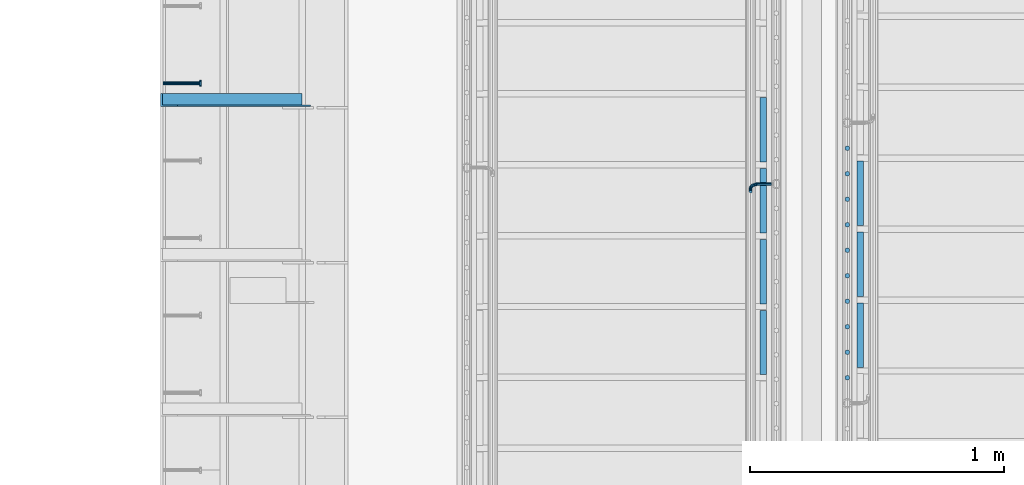
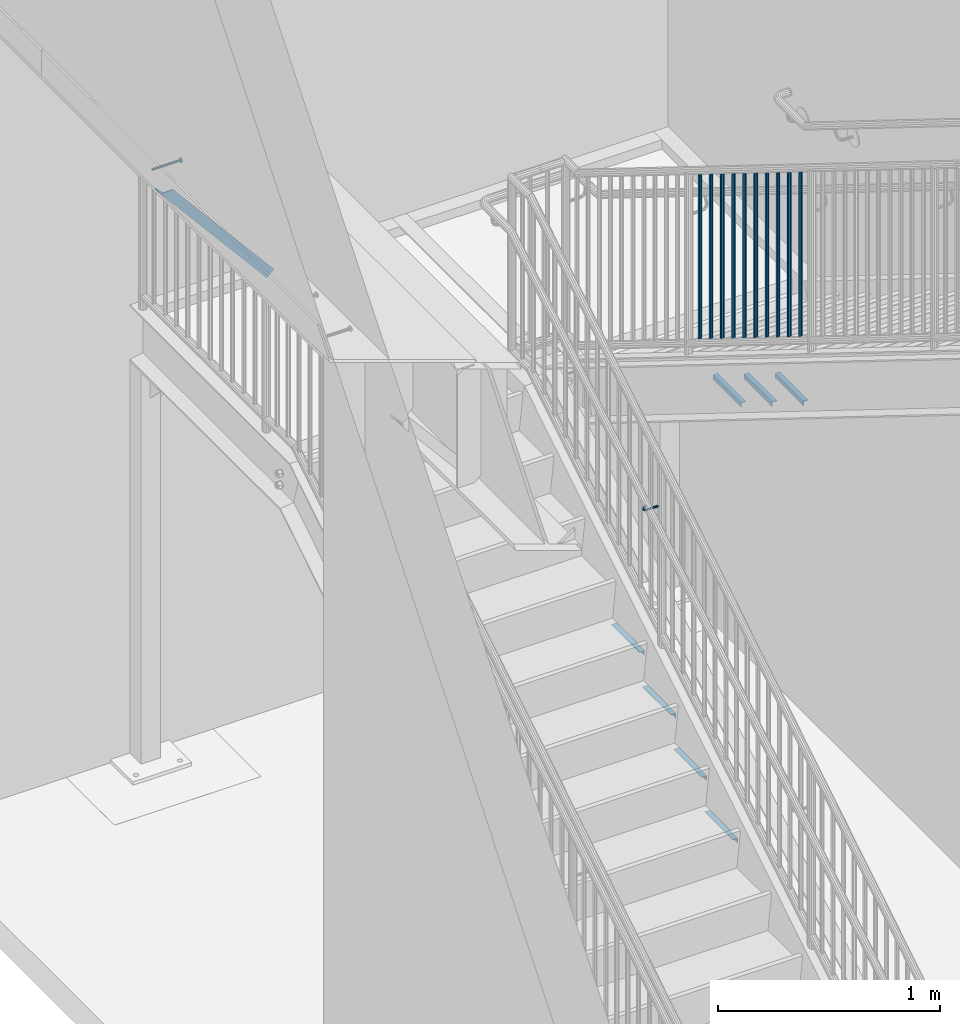
# One storey, part 1269 of 1763: 19 beams, 1 member, 6 elements without a shape of their own.
"""IFC2X3 building model written with IfcOpenShell, lengths in millimetres."""

from ifc_helpers import new_model, si_unit, frame, origin_with_axes, place, context, subcontext, project, spatial, faceted_brep, material, type_object, element, aggregate, save


model = new_model("IFC2X3")

# Units and contexts
model_context = context("Model", 3, precision=1e-05, world=origin_with_axes())
body_context = subcontext(model_context, "Body", "Model", "MODEL_VIEW")
ifc_project = project(units=[si_unit("LENGTHUNIT", "METRE", prefix="MILLI"), si_unit("AREAUNIT", "SQUARE_METRE"), si_unit("VOLUMEUNIT", "CUBIC_METRE"), si_unit("MASSUNIT", "GRAM", prefix="KILO"), si_unit("TIMEUNIT", "SECOND"), si_unit("PLANEANGLEUNIT", "RADIAN"), si_unit("SOLIDANGLEUNIT", "STERADIAN"), si_unit("THERMODYNAMICTEMPERATUREUNIT", "DEGREE_CELSIUS"), si_unit("LUMINOUSINTENSITYUNIT", "LUMEN")], contexts=[model_context])

# Site, building, storey
site_placement = place(None, origin_with_axes())
site = spatial("IfcSite", under=ifc_project, at=site_placement, CompositionType="ELEMENT")
building_placement = place(site_placement, origin_with_axes())
building = spatial("IfcBuilding", under=site, at=building_placement, Name="Undefined", CompositionType="ELEMENT")
storey_placement = place(building_placement, origin_with_axes())
storey = spatial("IfcBuildingStorey", under=building, at=storey_placement, Name="Undefined", CompositionType="ELEMENT", Elevation=0.0)

# Assembly, beam
assembly_1_placement = place(storey_placement, origin_with_axes())
assembly_1 = element("IfcElementAssembly", 1, at=assembly_1_placement, inside=storey, Name="HEADED STUD ANCHOR", AssemblyPlace="NOTDEFINED", PredefinedType="RIGID_FRAME")
ifc_material_1 = material(Name="STEEL/A108")
beam_type_1 = type_object("IfcBeamType", PredefinedType="NOTDEFINED")
beam_1_placement = place(assembly_1_placement, frame((-87975.5122736983, 35144.0750061035, 5268.91250001202), z_axis=(0.0, 0.0, -1.0), x_axis=(1.0, 0.0, 0.0)))
beam_1 = element("IfcBeam", 2, at=beam_1_placement, type_object=beam_type_1, material=ifc_material_1, Name="HEADED STUD ANCHOR", context=body_context, shape_type="Brep", body=[
    faceted_brep([(0.0, -3.1800000667572, 5.5), (0.0, -5.5, 3.1800000667572), (141.732000000002, -5.5, 3.1800000667572), (141.732000000002, -3.1800000667572, 5.5), (0.0, -6.34999999999491, 1.45519152283669e-11), (141.732000000002, -6.34999990463257, 0.0), (0.0, -5.5, -3.1800000667572), (141.732000000002, -5.5, -3.1800000667572), (0.0, -3.1800000667572, -5.5), (141.732000000002, -3.1800000667572, -5.5), (0.0, 0.0, -6.34999990463257), (141.732000000002, 0.0, -6.34999990463257), (0.0, 3.1800000667572, -5.5), (141.732000000002, 3.1800000667572, -5.5), (0.0, 5.5, -3.1800000667572), (141.732000000002, 5.5, -3.1800000667572), (0.0, 6.34999999999491, -2.91038304567337e-11), (141.732000000002, 6.34999990463257, 0.0), (0.0, 5.5, 3.1800000667572), (141.732000000002, 5.5, 3.1800000667572), (0.0, 3.1800000667572, 5.5), (141.732000000002, 3.1800000667572, 5.5), (0.0, 0.0, 6.34999990463257), (141.732000000002, 0.0, 6.34999990463257), (144.780000000001, -10.9899997711182, 6.34999990463257), (144.780000000001, -6.34000015258789, 10.9899997711182), (144.780000000001, -12.6999998092651, 0.0), (144.780000000001, -10.9899997711182, -6.34999990463257), (144.780000000001, -6.34000015258789, -10.9899997711182), (144.780000000001, 0.0, -12.6899995803833), (144.780000000001, 6.34000015258789, -10.9899997711182), (144.780000000001, 10.9899997711182, -6.34999990463257), (144.780000000001, 12.6999998092651, 0.0), (144.780000000001, 10.9899997711182, 6.34999990463257), (144.780000000001, 6.34000015258789, 10.9899997711182), (144.780000000001, 0.0, 12.6899995803833), (152.400000000001, -10.9899997711182, 6.34999990463257), (152.400000000001, -6.34000015258789, 10.9899997711182), (152.400000000001, -12.6999998092651, 0.0), (152.400000000001, -10.9899997711182, -6.34999990463257), (152.400000000001, -6.34000015258789, -10.9899997711182), (152.400000000001, 0.0, -12.6899995803833), (152.400000000001, 6.34000015258789, -10.9899997711182), (152.400000000001, 10.9899997711182, -6.34999990463257), (152.400000000001, 12.6999998092651, 0.0), (152.400000000001, 10.9899997711182, 6.34999990463257), (152.400000000001, 6.34000015258789, 10.9899997711182), (152.400000000001, 0.0, 12.6899995803833)], [[[0, 1, 2, 3]], [[1, 4, 5, 2]], [[4, 6, 7, 5]], [[6, 8, 9, 7]], [[8, 10, 11, 9]], [[10, 12, 13, 11]], [[12, 14, 15, 13]], [[14, 16, 17, 15]], [[16, 18, 19, 17]], [[18, 20, 21, 19]], [[20, 22, 23, 21]], [[22, 0, 3, 23]], [[22, 20, 18, 16, 14, 12, 10, 8, 6, 4, 1, 0]], [[3, 2, 24, 25]], [[2, 5, 26, 24]], [[5, 7, 27, 26]], [[7, 9, 28, 27]], [[9, 11, 29, 28]], [[11, 13, 30, 29]], [[13, 15, 31, 30]], [[15, 17, 32, 31]], [[17, 19, 33, 32]], [[19, 21, 34, 33]], [[21, 23, 35, 34]], [[23, 3, 25, 35]], [[25, 24, 36, 37]], [[24, 26, 38, 36]], [[26, 27, 39, 38]], [[27, 28, 40, 39]], [[28, 29, 41, 40]], [[29, 30, 42, 41]], [[30, 31, 43, 42]], [[31, 32, 44, 43]], [[32, 33, 45, 44]], [[33, 34, 46, 45]], [[34, 35, 47, 46]], [[35, 25, 37, 47]], [[38, 39, 40, 41, 42, 43, 44, 45, 46, 47, 37, 36]]]),
])
aggregate(assembly_1, [beam_1])

# Assembly, member
assembly_2_placement = place(storey_placement, origin_with_axes())
assembly_2 = element("IfcElementAssembly", 3, at=assembly_2_placement, inside=storey, Name="BEAM", AssemblyPlace="NOTDEFINED", PredefinedType="RIGID_FRAME")
ifc_material_2 = material(Name="STEEL/A36")
member_type = type_object("IfcMemberType", Name="L2X2X1/4", PredefinedType="NOTDEFINED")
member_placement = place(assembly_2_placement, frame((-87414.1929584935, 35077.4, 4557.35349338836), z_axis=(0.764183480307171, 0.0, 0.644998921259268), x_axis=(-0.644998921259266, 0.0, 0.764183480307173)))
member = element("IfcMember", 4, at=member_placement, type_object=member_type, material=ifc_material_2, Name="ANGLE", ObjectType="L2X2X1/4", context=body_context, shape_type="Brep", body=[
    faceted_brep([(-1.45519152283669e-11, 25.4000000000015, -25.3999999999869), (1.45519152283669e-11, 25.4000000000015, 25.3999999999796), (812.060911532491, 25.4000000000015, 25.400000001966), (854.937976763787, 25.4000000000015, -25.3999999979424), (1.45519152283669e-11, 19.0499999999993, 25.3999999999796), (812.060911532491, 19.0500000000029, 25.400000001966), (-7.27595761418343e-12, 19.0499999999993, -19.0499999999956), (849.578343609872, 19.0500000000029, -19.0499999979511), (-7.27595761418343e-12, -25.4000000000015, -19.0499999999956), (849.578343609872, -25.4000000000015, -19.0499999979511), (-1.45519152283669e-11, -25.4000000000015, -25.3999999999869), (854.937976763787, -25.4000000000015, -25.3999999979424)], [[[0, 1, 2, 3]], [[1, 4, 5, 2]], [[4, 6, 7, 5]], [[6, 8, 9, 7]], [[8, 10, 11, 9]], [[10, 0, 3, 11]], [[5, 7, 9, 11, 3, 2]], [[10, 8, 6, 4, 1, 0]]]),
])
aggregate(assembly_2, [member])

# Assembly, beam
assembly_3_placement = place(storey_placement, origin_with_axes())
assembly_3 = element("IfcElementAssembly", 5, at=assembly_3_placement, inside=storey, Name="RAIL", AssemblyPlace="NOTDEFINED", PredefinedType="RIGID_FRAME")
beam_type_2 = type_object("IfcBeamType", PredefinedType="NOTDEFINED")
beam_2_placement = place(assembly_3_placement, frame((-85578.3872739632, 34747.2000003714, 2823.89393381709), z_axis=(0.0, 0.849698797869672, 0.527268387919126), x_axis=(-1.0, 0.0, 0.0)))
beam_2 = element("IfcBeam", 6, at=beam_2_placement, type_object=beam_type_2, material=ifc_material_2, Name="RAIL", context=body_context, shape_type="Brep", body=[
    faceted_brep([(0.0, -6.34999999999491, 1.45519152283669e-11), (-1.13686837721616e-13, -4.49012806053361, -4.49012806058454), (50.8000030517578, -4.49012806053452, -4.49012806053361), (50.8000030517578, -6.35000000000036, 0.0), (0.0, 0.0, -6.34999990463257), (50.8000030517578, 0.0, -6.34999999999854), (0.0, 4.49012806054088, -4.49012806053452), (50.8000030517578, 4.49012806053452, -4.49012806053361), (0.0, 6.34999999999491, -2.91038304567337e-11), (50.8000030517578, 6.35000000000036, 0.0), (0.0, 4.49012806054088, 4.49012806053452), (50.8000030517578, 4.49012806053452, 4.49012806053361), (0.0, 0.0, 6.34999990463257), (50.8000030517578, 0.0, 6.34999999999854), (0.0, -4.49012806053361, 4.49012806055543), (50.8000030517578, -4.49012806053452, 4.49012806053361), (65.380241824867, -3.44981018867929, 0.0), (64.6684996473195, -1.73151257071549, 4.49012806053361), (62.9502020293439, 2.4168248427668, 6.34999999999854), (61.2319044113829, 6.5651622562491, 4.49012806053361), (60.5201622338354, 8.2834598742138, 0.0), (61.2319044113829, 6.5651622562491, -4.49012806053361), (62.9502020293439, 2.4168248427668, -6.34999999999854), (64.6684996473195, -1.73151257071549, -4.49012806053361), (76.425643354436, 6.12435969732724, -4.49012806053361), (77.7407714149595, 4.8092316367929, 0.0), (73.2506433544331, 9.29935969732742, -6.34999999999854), (70.0756433544302, 12.4743596973276, -4.49012806053361), (68.7605152938922, 13.7894877578619, 0.0), (70.0756433544302, 12.4743596973276, 4.49012806053361), (73.2506433544331, 9.29935969732742, 6.34999999999854), (76.425643354436, 6.12435969732724, 4.49012806053361), (84.2815156224679, 17.8815034044446, -4.49012806053361), (85.9998132404435, 17.1697612268908, 0.0), (80.1331782089983, 19.5998010224093, -6.34999999999854), (75.9848407955142, 21.3180986403731, -4.49012806053361), (74.2665431775386, 22.0298408179269, 0.0), (75.9848407955142, 21.3180986403731, 4.49012806053361), (80.1331782089983, 19.5998010224093, 6.34999999999854), (84.2815156224679, 17.8815034044446, 4.49012806053361), (87.0401311122987, 31.75, -4.49012806053361), (88.9000030517636, 31.75, 0.0), (82.5500030517578, 31.75, -6.34999999999854), (78.0598749912169, 31.75, -4.49012806053361), (76.200003051752, 31.75, 0.0), (78.0598749912169, 31.75, 4.49012806053361), (82.5500030517578, 31.75, 6.34999999999854), (87.0401311122987, 31.75, 4.49012806053361), (87.0401311122987, 57.1500015258789, -4.49012806053361), (88.9000030517636, 57.1500015258789, 0.0), (82.5500030517578, 57.1500015258789, -6.34999999999854), (78.0598749912169, 57.1500015258789, -4.49012806053361), (76.200003051752, 57.1500015258789, 0.0), (78.0598749912169, 57.1500015258789, 4.49012806053361), (82.5500030517578, 57.1500015258789, 6.34999999999854), (87.0401311122987, 57.1500015258789, 4.49012806053361)], [[[0, 1, 2, 3]], [[1, 4, 5, 2]], [[4, 6, 7, 5]], [[6, 8, 9, 7]], [[8, 10, 11, 9]], [[10, 12, 13, 11]], [[12, 14, 15, 13]], [[14, 0, 3, 15]], [[14, 12, 10, 8, 6, 4, 1, 0]], [[15, 3, 16, 17]], [[13, 15, 17, 18]], [[11, 13, 18, 19]], [[9, 11, 19, 20]], [[7, 9, 20, 21]], [[5, 7, 21, 22]], [[2, 5, 22, 23]], [[3, 2, 23, 16]], [[23, 24, 25, 16]], [[22, 26, 24, 23]], [[21, 27, 26, 22]], [[20, 28, 27, 21]], [[19, 29, 28, 20]], [[18, 30, 29, 19]], [[17, 31, 30, 18]], [[16, 25, 31, 17]], [[24, 32, 33, 25]], [[26, 34, 32, 24]], [[27, 35, 34, 26]], [[28, 36, 35, 27]], [[29, 37, 36, 28]], [[30, 38, 37, 29]], [[31, 39, 38, 30]], [[25, 33, 39, 31]], [[32, 40, 41, 33]], [[34, 42, 40, 32]], [[35, 43, 42, 34]], [[36, 44, 43, 35]], [[37, 45, 44, 36]], [[38, 46, 45, 37]], [[39, 47, 46, 38]], [[33, 41, 47, 39]], [[41, 40, 48, 49]], [[40, 42, 50, 48]], [[42, 43, 51, 50]], [[43, 44, 52, 51]], [[44, 45, 53, 52]], [[45, 46, 54, 53]], [[46, 47, 55, 54]], [[47, 41, 49, 55]], [[50, 51, 52, 53, 54, 55, 49, 48]]]),
])
aggregate(assembly_3, [beam_2])

# Assembly, beams
assembly_4_placement = place(storey_placement, origin_with_axes())
assembly_4 = element("IfcElementAssembly", 7, at=assembly_4_placement, inside=storey, Name="RAIL", AssemblyPlace="NOTDEFINED", PredefinedType="RIGID_FRAME")
beam_type_3 = type_object("IfcBeamType", PredefinedType="NOTDEFINED")
beam_3_placement = place(assembly_4_placement, frame((-85279.8721005486, 33984.0454545575, 5037.48386342587), z_axis=(1.0, 0.0, 0.0), x_axis=(0.0, 0.0, -1.0)))
beam_3 = element("IfcBeam", 8, at=beam_3_placement, type_object=beam_type_3, material=ifc_material_2, Name="PICKET", context=body_context, shape_type="Brep", body=[
    faceted_brep([(16.5092624764411, -9.52500000000146, 0.0), (18.2412682186596, -6.73519209080041, -6.73519209079677), (919.54586829654, -6.73519209080041, -6.73519209079677), (917.813862554322, -9.52500000000146, 0.0), (22.4226999716293, 0.0, -9.52499999999418), (923.727300049511, 0.0, -9.52499999999418), (26.6041317245999, 6.73519209080041, -6.73519209079677), (927.908731802481, 6.73519209080041, -6.73519209079677), (28.3361374668184, 9.52500000000146, 0.0), (929.6407375447, 9.52500000000146, 0.0), (26.6041317245999, 6.73519209080041, 6.73519209079677), (927.908731802481, 6.73519209080041, 6.73519209079677), (22.4226999716293, 0.0, 9.52499999999418), (923.727300049511, 0.0, 9.52499999999418), (18.2412682186596, -6.73519209080041, 6.73519209079677), (919.54586829654, -6.73519209080041, 6.73519209079677)], [[[0, 1, 2, 3]], [[1, 4, 5, 2]], [[4, 6, 7, 5]], [[6, 8, 9, 7]], [[8, 10, 11, 9]], [[10, 12, 13, 11]], [[12, 14, 15, 13]], [[14, 0, 3, 15]], [[5, 7, 9, 11, 13, 15, 3, 2]], [[14, 12, 10, 8, 6, 4, 1, 0]]]),
])
beam_4_placement = place(assembly_4_placement, frame((-85279.8721005486, 34084.4909091201, 4975.12397710232), z_axis=(1.0, 0.0, 0.0), x_axis=(0.0, 0.0, -1.0)))
beam_4 = element("IfcBeam", 9, at=beam_4_placement, type_object=beam_type_3, material=ifc_material_2, Name="PICKET", context=body_context, shape_type="Brep", body=[
    faceted_brep([(16.5092624764411, -9.52500000000146, 0.0), (18.2412682186596, -6.73519209080041, -6.73519209079677), (919.54586829654, -6.73519209080041, -6.73519209079677), (917.813862554322, -9.52500000000146, 0.0), (22.4226999716293, 0.0, -9.52499999999418), (923.727300049511, 0.0, -9.52499999999418), (26.6041317245999, 6.73519209080041, -6.73519209079677), (927.908731802481, 6.73519209080041, -6.73519209079677), (28.3361374668184, 9.52500000000146, 0.0), (929.6407375447, 9.52500000000146, 0.0), (26.6041317245999, 6.73519209080041, 6.73519209079677), (927.908731802481, 6.73519209080041, 6.73519209079677), (22.4226999716293, 0.0, 9.52499999999418), (923.727300049511, 0.0, 9.52499999999418), (18.2412682186596, -6.73519209080041, 6.73519209079677), (919.54586829654, -6.73519209080041, 6.73519209079677)], [[[0, 1, 2, 3]], [[1, 4, 5, 2]], [[4, 6, 7, 5]], [[6, 8, 9, 7]], [[8, 10, 11, 9]], [[10, 12, 13, 11]], [[12, 14, 15, 13]], [[14, 0, 3, 15]], [[5, 7, 9, 11, 13, 15, 3, 2]], [[14, 12, 10, 8, 6, 4, 1, 0]]]),
])
beam_5_placement = place(assembly_4_placement, frame((-85279.8721005486, 34184.9363636827, 4912.76409077877), z_axis=(1.0, 0.0, 0.0), x_axis=(0.0, 0.0, -1.0)))
beam_5 = element("IfcBeam", 10, at=beam_5_placement, type_object=beam_type_3, material=ifc_material_2, Name="PICKET", context=body_context, shape_type="Brep", body=[
    faceted_brep([(16.5092624764411, -9.52500000000146, 0.0), (18.2412682186596, -6.73519209080041, -6.73519209079677), (919.54586829654, -6.73519209080041, -6.73519209079677), (917.813862554322, -9.52500000000146, 0.0), (22.4226999716293, 0.0, -9.52499999999418), (923.727300049511, 0.0, -9.52499999999418), (26.6041317245999, 6.73519209080041, -6.73519209079677), (927.908731802481, 6.73519209080041, -6.73519209079677), (28.3361374668184, 9.52500000000146, 0.0), (929.6407375447, 9.52500000000146, 0.0), (26.6041317245999, 6.73519209080041, 6.73519209079677), (927.908731802481, 6.73519209080041, 6.73519209079677), (22.4226999716293, 0.0, 9.52499999999418), (923.727300049511, 0.0, 9.52499999999418), (18.2412682186596, -6.73519209080041, 6.73519209079677), (919.54586829654, -6.73519209080041, 6.73519209079677)], [[[0, 1, 2, 3]], [[1, 4, 5, 2]], [[4, 6, 7, 5]], [[6, 8, 9, 7]], [[8, 10, 11, 9]], [[10, 12, 13, 11]], [[12, 14, 15, 13]], [[14, 0, 3, 15]], [[5, 7, 9, 11, 13, 15, 3, 2]], [[14, 12, 10, 8, 6, 4, 1, 0]]]),
])
beam_6_placement = place(assembly_4_placement, frame((-85279.8721005486, 34285.3818182453, 4850.40420445523), z_axis=(1.0, 0.0, 0.0), x_axis=(0.0, 0.0, -1.0)))
beam_6 = element("IfcBeam", 11, at=beam_6_placement, type_object=beam_type_3, material=ifc_material_2, Name="PICKET", context=body_context, shape_type="Brep", body=[
    faceted_brep([(16.5092624764411, -9.52500000000146, 0.0), (18.2412682186596, -6.73519209080041, -6.73519209079677), (919.54586829654, -6.73519209080041, -6.73519209079677), (917.813862554322, -9.52500000000146, 0.0), (22.4226999716293, 0.0, -9.52499999999418), (923.727300049511, 0.0, -9.52499999999418), (26.6041317245999, 6.73519209080041, -6.73519209079677), (927.908731802481, 6.73519209080041, -6.73519209079677), (28.3361374668184, 9.52500000000146, 0.0), (929.6407375447, 9.52500000000146, 0.0), (26.6041317245999, 6.73519209080041, 6.73519209079677), (927.908731802481, 6.73519209080041, 6.73519209079677), (22.4226999716293, 0.0, 9.52499999999418), (923.727300049511, 0.0, 9.52499999999418), (18.2412682186596, -6.73519209080041, 6.73519209079677), (919.54586829654, -6.73519209080041, 6.73519209079677)], [[[0, 1, 2, 3]], [[1, 4, 5, 2]], [[4, 6, 7, 5]], [[6, 8, 9, 7]], [[8, 10, 11, 9]], [[10, 12, 13, 11]], [[12, 14, 15, 13]], [[14, 0, 3, 15]], [[5, 7, 9, 11, 13, 15, 3, 2]], [[14, 12, 10, 8, 6, 4, 1, 0]]]),
])
beam_7_placement = place(assembly_4_placement, frame((-85279.8721005486, 34385.8272728079, 4788.04431813168), z_axis=(1.0, 0.0, 0.0), x_axis=(0.0, 0.0, -1.0)))
beam_7 = element("IfcBeam", 12, at=beam_7_placement, type_object=beam_type_3, material=ifc_material_2, Name="PICKET", context=body_context, shape_type="Brep", body=[
    faceted_brep([(16.5092624764411, -9.52500000000146, 0.0), (18.2412682186596, -6.73519209080041, -6.73519209079677), (919.54586829654, -6.73519209080041, -6.73519209079677), (917.813862554322, -9.52500000000146, 0.0), (22.4226999716293, 0.0, -9.52499999999418), (923.727300049511, 0.0, -9.52499999999418), (26.6041317245999, 6.73519209080041, -6.73519209079677), (927.908731802481, 6.73519209080041, -6.73519209079677), (28.3361374668184, 9.52500000000146, 0.0), (929.6407375447, 9.52500000000146, 0.0), (26.6041317245999, 6.73519209080041, 6.73519209079677), (927.908731802481, 6.73519209080041, 6.73519209079677), (22.4226999716293, 0.0, 9.52499999999418), (923.727300049511, 0.0, 9.52499999999418), (18.2412682186596, -6.73519209080041, 6.73519209079677), (919.54586829654, -6.73519209080041, 6.73519209079677)], [[[0, 1, 2, 3]], [[1, 4, 5, 2]], [[4, 6, 7, 5]], [[6, 8, 9, 7]], [[8, 10, 11, 9]], [[10, 12, 13, 11]], [[12, 14, 15, 13]], [[14, 0, 3, 15]], [[5, 7, 9, 11, 13, 15, 3, 2]], [[14, 12, 10, 8, 6, 4, 1, 0]]]),
])
beam_8_placement = place(assembly_4_placement, frame((-85279.8721005486, 34486.2727273705, 4725.68443180813), z_axis=(1.0, 0.0, 0.0), x_axis=(0.0, 0.0, -1.0)))
beam_8 = element("IfcBeam", 13, at=beam_8_placement, type_object=beam_type_3, material=ifc_material_2, Name="PICKET", context=body_context, shape_type="Brep", body=[
    faceted_brep([(16.5092624764411, -9.52500000000146, 0.0), (18.2412682186596, -6.73519209080041, -6.73519209079677), (919.54586829654, -6.73519209080041, -6.73519209079677), (917.813862554322, -9.52500000000146, 0.0), (22.4226999716293, 0.0, -9.52499999999418), (923.727300049511, 0.0, -9.52499999999418), (26.6041317245999, 6.73519209080041, -6.73519209079677), (927.908731802481, 6.73519209080041, -6.73519209079677), (28.3361374668184, 9.52500000000146, 0.0), (929.6407375447, 9.52500000000146, 0.0), (26.6041317245999, 6.73519209080041, 6.73519209079677), (927.908731802481, 6.73519209080041, 6.73519209079677), (22.4226999716293, 0.0, 9.52499999999418), (923.727300049511, 0.0, 9.52499999999418), (18.2412682186596, -6.73519209080041, 6.73519209079677), (919.54586829654, -6.73519209080041, 6.73519209079677)], [[[0, 1, 2, 3]], [[1, 4, 5, 2]], [[4, 6, 7, 5]], [[6, 8, 9, 7]], [[8, 10, 11, 9]], [[10, 12, 13, 11]], [[12, 14, 15, 13]], [[14, 0, 3, 15]], [[5, 7, 9, 11, 13, 15, 3, 2]], [[14, 12, 10, 8, 6, 4, 1, 0]]]),
])
beam_9_placement = place(assembly_4_placement, frame((-85279.8721005486, 34586.7181819331, 4663.32454548458), z_axis=(1.0, 0.0, 0.0), x_axis=(0.0, 0.0, -1.0)))
beam_9 = element("IfcBeam", 14, at=beam_9_placement, type_object=beam_type_3, material=ifc_material_2, Name="PICKET", context=body_context, shape_type="Brep", body=[
    faceted_brep([(16.5092624764411, -9.52500000000146, 0.0), (18.2412682186596, -6.73519209080041, -6.73519209079677), (919.54586829654, -6.73519209080041, -6.73519209079677), (917.813862554322, -9.52500000000146, 0.0), (22.4226999716293, 0.0, -9.52499999999418), (923.727300049511, 0.0, -9.52499999999418), (26.6041317245999, 6.73519209080041, -6.73519209079677), (927.908731802481, 6.73519209080041, -6.73519209079677), (28.3361374668184, 9.52500000000146, 0.0), (929.6407375447, 9.52500000000146, 0.0), (26.6041317245999, 6.73519209080041, 6.73519209079677), (927.908731802481, 6.73519209080041, 6.73519209079677), (22.4226999716293, 0.0, 9.52499999999418), (923.727300049511, 0.0, 9.52499999999418), (18.2412682186596, -6.73519209080041, 6.73519209079677), (919.54586829654, -6.73519209080041, 6.73519209079677)], [[[0, 1, 2, 3]], [[1, 4, 5, 2]], [[4, 6, 7, 5]], [[6, 8, 9, 7]], [[8, 10, 11, 9]], [[10, 12, 13, 11]], [[12, 14, 15, 13]], [[14, 0, 3, 15]], [[5, 7, 9, 11, 13, 15, 3, 2]], [[14, 12, 10, 8, 6, 4, 1, 0]]]),
])
beam_10_placement = place(assembly_4_placement, frame((-85279.8721005486, 34687.1636364957, 4600.96465916103), z_axis=(1.0, 0.0, 0.0), x_axis=(0.0, 0.0, -1.0)))
beam_10 = element("IfcBeam", 15, at=beam_10_placement, type_object=beam_type_3, material=ifc_material_2, Name="PICKET", context=body_context, shape_type="Brep", body=[
    faceted_brep([(16.5092624764411, -9.52500000000146, 0.0), (18.2412682186596, -6.73519209080041, -6.73519209079677), (919.54586829654, -6.73519209080041, -6.73519209079677), (917.813862554322, -9.52500000000146, 0.0), (22.4226999716293, 0.0, -9.52499999999418), (923.727300049511, 0.0, -9.52499999999418), (26.6041317245999, 6.73519209080041, -6.73519209079677), (927.908731802481, 6.73519209080041, -6.73519209079677), (28.3361374668184, 9.52500000000146, 0.0), (929.6407375447, 9.52500000000146, 0.0), (26.6041317245999, 6.73519209080041, 6.73519209079677), (927.908731802481, 6.73519209080041, 6.73519209079677), (22.4226999716293, 0.0, 9.52499999999418), (923.727300049511, 0.0, 9.52499999999418), (18.2412682186596, -6.73519209080041, 6.73519209079677), (919.54586829654, -6.73519209080041, 6.73519209079677)], [[[0, 1, 2, 3]], [[1, 4, 5, 2]], [[4, 6, 7, 5]], [[6, 8, 9, 7]], [[8, 10, 11, 9]], [[10, 12, 13, 11]], [[12, 14, 15, 13]], [[14, 0, 3, 15]], [[5, 7, 9, 11, 13, 15, 3, 2]], [[14, 12, 10, 8, 6, 4, 1, 0]]]),
])
beam_11_placement = place(assembly_4_placement, frame((-85279.8721005486, 34787.6090910583, 4538.60477283749), z_axis=(1.0, 0.0, 0.0), x_axis=(0.0, 0.0, -1.0)))
beam_11 = element("IfcBeam", 16, at=beam_11_placement, type_object=beam_type_3, material=ifc_material_2, Name="PICKET", context=body_context, shape_type="Brep", body=[
    faceted_brep([(16.5092624764411, -9.52500000000146, 0.0), (18.2412682186596, -6.73519209080041, -6.73519209079677), (919.54586829654, -6.73519209080041, -6.73519209079677), (917.813862554322, -9.52500000000146, 0.0), (22.4226999716293, 0.0, -9.52499999999418), (923.727300049511, 0.0, -9.52499999999418), (26.6041317245999, 6.73519209080041, -6.73519209079677), (927.908731802481, 6.73519209080041, -6.73519209079677), (28.3361374668184, 9.52500000000146, 0.0), (929.6407375447, 9.52500000000146, 0.0), (26.6041317245999, 6.73519209080041, 6.73519209079677), (927.908731802481, 6.73519209080041, 6.73519209079677), (22.4226999716293, 0.0, 9.52499999999418), (923.727300049511, 0.0, 9.52499999999418), (18.2412682186596, -6.73519209080041, 6.73519209079677), (919.54586829654, -6.73519209080041, 6.73519209079677)], [[[0, 1, 2, 3]], [[1, 4, 5, 2]], [[4, 6, 7, 5]], [[6, 8, 9, 7]], [[8, 10, 11, 9]], [[10, 12, 13, 11]], [[12, 14, 15, 13]], [[14, 0, 3, 15]], [[5, 7, 9, 11, 13, 15, 3, 2]], [[14, 12, 10, 8, 6, 4, 1, 0]]]),
])
beam_12_placement = place(assembly_4_placement, frame((-85279.8721005486, 34888.054545621, 4476.24488651394), z_axis=(1.0, 0.0, 0.0), x_axis=(0.0, 0.0, -1.0)))
beam_12 = element("IfcBeam", 17, at=beam_12_placement, type_object=beam_type_3, material=ifc_material_2, Name="PICKET", context=body_context, shape_type="Brep", body=[
    faceted_brep([(16.5092624764411, -9.52500000000146, 0.0), (18.2412682186596, -6.73519209080041, -6.73519209079677), (919.54586829654, -6.73519209080041, -6.73519209079677), (917.813862554322, -9.52500000000146, 0.0), (22.4226999716293, 0.0, -9.52499999999418), (923.727300049511, 0.0, -9.52499999999418), (26.6041317245999, 6.73519209080041, -6.73519209079677), (927.908731802481, 6.73519209080041, -6.73519209079677), (28.3361374668184, 9.52500000000146, 0.0), (929.6407375447, 9.52500000000146, 0.0), (26.6041317245999, 6.73519209080041, 6.73519209079677), (927.908731802481, 6.73519209080041, 6.73519209079677), (22.4226999716293, 0.0, 9.52499999999418), (923.727300049511, 0.0, 9.52499999999418), (18.2412682186596, -6.73519209080041, 6.73519209079677), (919.54586829654, -6.73519209080041, 6.73519209079677)], [[[0, 1, 2, 3]], [[1, 4, 5, 2]], [[4, 6, 7, 5]], [[6, 8, 9, 7]], [[8, 10, 11, 9]], [[10, 12, 13, 11]], [[12, 14, 15, 13]], [[14, 0, 3, 15]], [[5, 7, 9, 11, 13, 15, 3, 2]], [[14, 12, 10, 8, 6, 4, 1, 0]]]),
])
aggregate(assembly_4, [beam_3, beam_4, beam_5, beam_6, beam_7, beam_8, beam_9, beam_10, beam_11, beam_12])

# Assembly, beam
assembly_5_placement = place(storey_placement, origin_with_axes())
assembly_5 = element("IfcElementAssembly", 18, at=assembly_5_placement, inside=storey, Name="STRINGER", AssemblyPlace="NOTDEFINED", PredefinedType="RIGID_FRAME")
beam_type_4 = type_object("IfcBeamType", Name="L1X1X1/8", PredefinedType="NOTDEFINED")
beam_13_placement = place(assembly_5_placement, frame((-85229.072101503, 34025.3524600038, 3706.17750020325), z_axis=(1.0, 0.0, 0.0), x_axis=(0.0, 1.0, 0.0)))
beam_13 = element("IfcBeam", 19, at=beam_13_placement, type_object=beam_type_4, material=ifc_material_2, Name="ANGLE", ObjectType="L1X1X1/8", context=body_context, shape_type="Brep", body=[
    faceted_brep([(3.93434019839663e-12, 12.6999999999978, -12.6999998092651), (-1.31614667686587e-12, 12.6999999999978, 12.6999998092651), (254.0, 12.69999981, 12.6999998099927), (254.0, 12.69999981, -12.6999998099927), (-1.06936913171421e-12, 9.52499999999854, 12.699999332428), (254.0, 9.52499985799977, 12.6999998099927), (0.0, 9.52499985799977, -9.52499985799659), (254.0, 9.52499985799977, -9.52499985799659), (0.0, -12.69999981, -9.52499985799659), (254.0, -12.69999981, -9.52499985799659), (0.0, -12.69999981, -12.6999998099927), (254.0, -12.69999981, -12.6999998099927)], [[[0, 1, 2, 3]], [[1, 4, 5, 2]], [[4, 6, 7, 5]], [[6, 8, 9, 7]], [[8, 10, 11, 9]], [[10, 0, 3, 11]], [[5, 7, 9, 11, 3, 2]], [[10, 8, 6, 4, 1, 0]]]),
])

# Assembly, beams
assembly_6_placement = place(storey_placement, origin_with_axes())
assembly_6 = element("IfcElementAssembly", 20, at=assembly_6_placement, inside=storey, Name="STRINGER", AssemblyPlace="NOTDEFINED", PredefinedType="RIGID_FRAME")
beam_14_placement = place(assembly_6_placement, frame((-85610.137273544, 35088.0511407179, 1971.90178590486), z_axis=(-1.0, 0.0, 0.0), x_axis=(0.0, -1.0, 0.0)))
beam_14 = element("IfcBeam", 21, at=beam_14_placement, type_object=beam_type_4, material=ifc_material_2, Name="ANGLE", ObjectType="L1X1X1/8", context=body_context, shape_type="Brep", body=[
    faceted_brep([(3.93434019839663e-12, 12.6999999999978, -12.6999998092651), (-1.31614667686587e-12, 12.6999999999978, 12.6999998092651), (254.0, 12.69999981, 12.6999998099927), (254.0, 12.69999981, -12.6999998099927), (-1.06936913171421e-12, 9.52499999999854, 12.699999332428), (254.0, 9.52499985799977, 12.6999998099927), (0.0, 9.52499985799977, -9.52499985799659), (254.0, 9.52499985799977, -9.52499985799659), (0.0, -12.69999981, -9.52499985799659), (254.0, -12.69999981, -9.52499985799659), (0.0, -12.69999981, -12.6999998099927), (254.0, -12.69999981, -12.6999998099927)], [[[0, 1, 2, 3]], [[1, 4, 5, 2]], [[4, 6, 7, 5]], [[6, 8, 9, 7]], [[8, 10, 11, 9]], [[10, 0, 3, 11]], [[5, 7, 9, 11, 3, 2]], [[10, 8, 6, 4, 1, 0]]]),
])
beam_15_placement = place(assembly_6_placement, frame((-85610.137273544, 34808.6511407179, 1798.52410733343), z_axis=(-1.0, 0.0, 0.0), x_axis=(0.0, -1.0, 0.0)))
beam_15 = element("IfcBeam", 22, at=beam_15_placement, type_object=beam_type_4, material=ifc_material_2, Name="ANGLE", ObjectType="L1X1X1/8", context=body_context, shape_type="Brep", body=[
    faceted_brep([(3.93434019839663e-12, 12.6999999999978, -12.6999998092651), (-1.31614667686587e-12, 12.6999999999978, 12.6999998092651), (254.0, 12.69999981, 12.6999998099927), (254.0, 12.69999981, -12.6999998099927), (-1.06936913171421e-12, 9.52499999999854, 12.699999332428), (254.0, 9.52499985799977, 12.6999998099927), (0.0, 9.52499985799977, -9.52499985799659), (254.0, 9.52499985799977, -9.52499985799659), (0.0, -12.69999981, -9.52499985799659), (254.0, -12.69999981, -9.52499985799659), (0.0, -12.69999981, -12.6999998099927), (254.0, -12.69999981, -12.6999998099927)], [[[0, 1, 2, 3]], [[1, 4, 5, 2]], [[4, 6, 7, 5]], [[6, 8, 9, 7]], [[8, 10, 11, 9]], [[10, 0, 3, 11]], [[5, 7, 9, 11, 3, 2]], [[10, 8, 6, 4, 1, 0]]]),
])
beam_16_placement = place(assembly_6_placement, frame((-85610.137273544, 34529.2511407179, 1625.146428762), z_axis=(-1.0, 0.0, 0.0), x_axis=(0.0, -1.0, 0.0)))
beam_16 = element("IfcBeam", 23, at=beam_16_placement, type_object=beam_type_4, material=ifc_material_2, Name="ANGLE", ObjectType="L1X1X1/8", context=body_context, shape_type="Brep", body=[
    faceted_brep([(3.93434019839663e-12, 12.6999999999978, -12.6999998092651), (-1.31614667686587e-12, 12.6999999999978, 12.6999998092651), (254.0, 12.69999981, 12.6999998099927), (254.0, 12.69999981, -12.6999998099927), (-1.06936913171421e-12, 9.52499999999854, 12.699999332428), (254.0, 9.52499985799977, 12.6999998099927), (0.0, 9.52499985799977, -9.52499985799659), (254.0, 9.52499985799977, -9.52499985799659), (0.0, -12.69999981, -9.52499985799659), (254.0, -12.69999981, -9.52499985799659), (0.0, -12.69999981, -12.6999998099927), (254.0, -12.69999981, -12.6999998099927)], [[[0, 1, 2, 3]], [[1, 4, 5, 2]], [[4, 6, 7, 5]], [[6, 8, 9, 7]], [[8, 10, 11, 9]], [[10, 0, 3, 11]], [[5, 7, 9, 11, 3, 2]], [[10, 8, 6, 4, 1, 0]]]),
])
beam_17_placement = place(assembly_6_placement, frame((-85610.137273544, 34249.8511407179, 1451.76875019058), z_axis=(-1.0, 0.0, 0.0), x_axis=(0.0, -1.0, 0.0)))
beam_17 = element("IfcBeam", 24, at=beam_17_placement, type_object=beam_type_4, material=ifc_material_2, Name="ANGLE", ObjectType="L1X1X1/8", context=body_context, shape_type="Brep", body=[
    faceted_brep([(3.93434019839663e-12, 12.6999999999978, -12.6999998092651), (-1.31614667686587e-12, 12.6999999999978, 12.6999998092651), (254.0, 12.69999981, 12.6999998099927), (254.0, 12.69999981, -12.6999998099927), (-1.06936913171421e-12, 9.52499999999854, 12.699999332428), (254.0, 9.52499985799977, 12.6999998099927), (0.0, 9.52499985799977, -9.52499985799659), (254.0, 9.52499985799977, -9.52499985799659), (0.0, -12.69999981, -9.52499985799659), (254.0, -12.69999981, -9.52499985799659), (0.0, -12.69999981, -12.6999998099927), (254.0, -12.69999981, -12.6999998099927)], [[[0, 1, 2, 3]], [[1, 4, 5, 2]], [[4, 6, 7, 5]], [[6, 8, 9, 7]], [[8, 10, 11, 9]], [[10, 0, 3, 11]], [[5, 7, 9, 11, 3, 2]], [[10, 8, 6, 4, 1, 0]]]),
])
aggregate(assembly_6, [beam_14, beam_15, beam_16, beam_17])

# Beam
beam_18_placement = place(assembly_5_placement, frame((-85229.072101503, 34304.7524600877, 3532.71666686991), z_axis=(1.0, 0.0, 0.0), x_axis=(0.0, 1.0, 0.0)))
beam_18 = element("IfcBeam", 25, at=beam_18_placement, type_object=beam_type_4, material=ifc_material_2, Name="ANGLE", ObjectType="L1X1X1/8", context=body_context, shape_type="Brep", body=[
    faceted_brep([(3.93434019839663e-12, 12.6999999999978, -12.6999998092651), (-1.31614667686587e-12, 12.6999999999978, 12.6999998092651), (254.0, 12.69999981, 12.6999998099927), (254.0, 12.69999981, -12.6999998099927), (-1.06936913171421e-12, 9.52499999999854, 12.699999332428), (254.0, 9.52499985799977, 12.6999998099927), (0.0, 9.52499985799977, -9.52499985799659), (254.0, 9.52499985799977, -9.52499985799659), (0.0, -12.69999981, -9.52499985799659), (254.0, -12.69999981, -9.52499985799659), (0.0, -12.69999981, -12.6999998099927), (254.0, -12.69999981, -12.6999998099927)], [[[0, 1, 2, 3]], [[1, 4, 5, 2]], [[4, 6, 7, 5]], [[6, 8, 9, 7]], [[8, 10, 11, 9]], [[10, 0, 3, 11]], [[5, 7, 9, 11, 3, 2]], [[10, 8, 6, 4, 1, 0]]]),
])

beam_19_placement = place(assembly_5_placement, frame((-85229.072101503, 34584.1524601716, 3359.25583353658), z_axis=(1.0, 0.0, 0.0), x_axis=(0.0, 1.0, 0.0)))
beam_19 = element("IfcBeam", 26, at=beam_19_placement, type_object=beam_type_4, material=ifc_material_2, Name="ANGLE", ObjectType="L1X1X1/8", context=body_context, shape_type="Brep", body=[
    faceted_brep([(3.93434019839663e-12, 12.6999999999978, -12.6999998092651), (-1.31614667686587e-12, 12.6999999999978, 12.6999998092651), (254.0, 12.69999981, 12.6999998099927), (254.0, 12.69999981, -12.6999998099927), (-1.06936913171421e-12, 9.52499999999854, 12.699999332428), (254.0, 9.52499985799977, 12.6999998099927), (0.0, 9.52499985799977, -9.52499985799659), (254.0, 9.52499985799977, -9.52499985799659), (0.0, -12.69999981, -9.52499985799659), (254.0, -12.69999981, -9.52499985799659), (0.0, -12.69999981, -12.6999998099927), (254.0, -12.69999981, -12.6999998099927)], [[[0, 1, 2, 3]], [[1, 4, 5, 2]], [[4, 6, 7, 5]], [[6, 8, 9, 7]], [[8, 10, 11, 9]], [[10, 0, 3, 11]], [[5, 7, 9, 11, 3, 2]], [[10, 8, 6, 4, 1, 0]]]),
])

aggregate(assembly_5, [beam_13, beam_18, beam_19])

save(model, "model.ifc")
